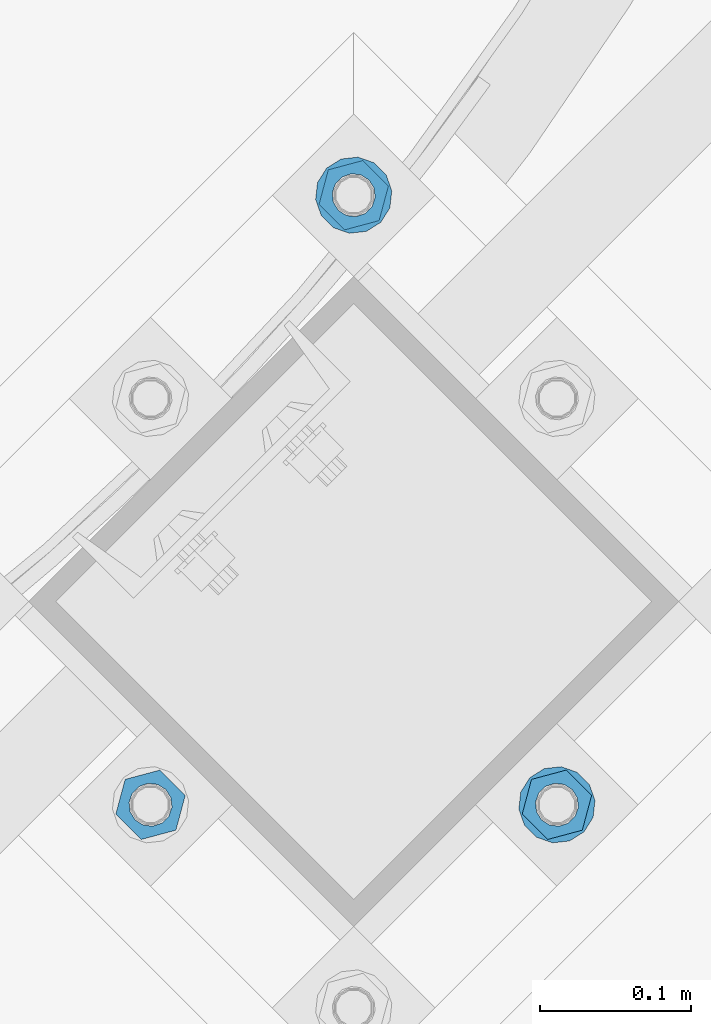
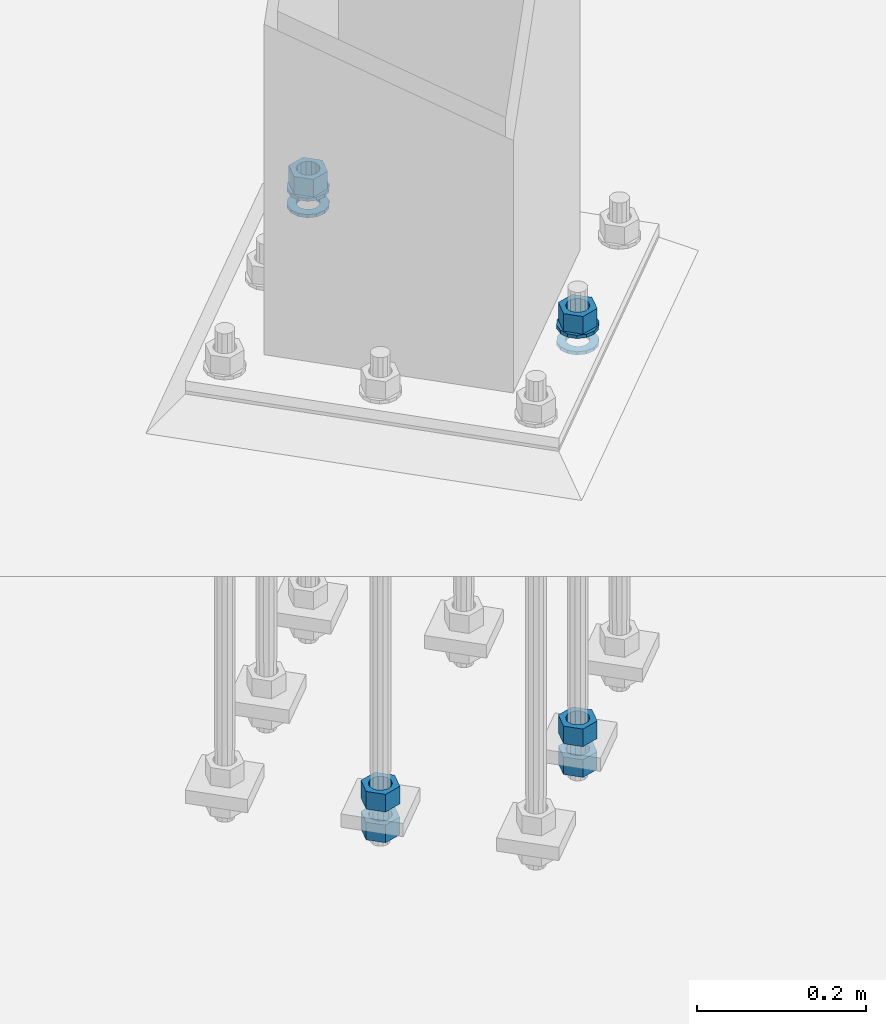
# One storey, part 882 of 1876: 10 columns, 1 element without a shape of its own.
"""IFC2X3 building model written with IfcOpenShell, lengths in millimetres."""

from ifc_helpers import new_model, si_unit, frame, origin_with_axes, place, context, subcontext, project, spatial, faceted_brep, material, type_object, element, aggregate, save


model = new_model("IFC2X3")

# Units and contexts
model_context = context("Model", 3, precision=1e-05, world=origin_with_axes())
body_context = subcontext(model_context, "Body", "Model", "MODEL_VIEW")
ifc_project = project(units=[si_unit("LENGTHUNIT", "METRE", prefix="MILLI"), si_unit("AREAUNIT", "SQUARE_METRE"), si_unit("VOLUMEUNIT", "CUBIC_METRE"), si_unit("MASSUNIT", "GRAM", prefix="KILO"), si_unit("TIMEUNIT", "SECOND"), si_unit("PLANEANGLEUNIT", "RADIAN"), si_unit("SOLIDANGLEUNIT", "STERADIAN"), si_unit("THERMODYNAMICTEMPERATUREUNIT", "DEGREE_CELSIUS"), si_unit("LUMINOUSINTENSITYUNIT", "LUMEN")], contexts=[model_context])

# Site, building, storey
site_placement = place(None, origin_with_axes())
site = spatial("IfcSite", under=ifc_project, at=site_placement, CompositionType="ELEMENT")
building_placement = place(site_placement, origin_with_axes())
building = spatial("IfcBuilding", under=site, at=building_placement, Name="Undefined", CompositionType="ELEMENT")
storey_placement = place(building_placement, origin_with_axes())
storey = spatial("IfcBuildingStorey", under=building, at=storey_placement, Name="Undefined", CompositionType="ELEMENT", Elevation=0.0)

# Assembly, columns
assembly_placement = place(storey_placement, origin_with_axes())
assembly = element("IfcElementAssembly", 1, at=assembly_placement, inside=storey, Name="TEMPLATE", AssemblyPlace="NOTDEFINED", PredefinedType="RIGID_FRAME")
ifc_material_1 = material(Name="STEEL/A563")
column_type_1 = type_object("IfcColumnType", Name="1_HEAVY_HEX_NUT", PredefinedType="NOTDEFINED")
column_1_placement = place(assembly_placement, frame((6580.27820529301, -10666.824706778, 87.3125), z_axis=(-0.707106781186547, -0.707106781186548, 0.0), x_axis=(0.0, 0.0, -1.0)))
column_1 = element("IfcColumn", 2, at=column_1_placement, type_object=column_type_1, material=ifc_material_1, Name="NUT", ObjectType="1_HEAVY_HEX_NUT", context=body_context, shape_type="Brep", body=[
    faceted_brep([(0.0, -23.8099994659442, 9.09494701772928e-13), (0.0, -11.9099998474121, -20.6200008392352), (25.4, -11.9099998474157, -20.6200008392361), (25.4, -23.8099994659478, 0.0), (0.0, 11.9099998474157, -20.620000839237), (25.4, 11.9099998474121, -20.620000839237), (0.0, 23.8099994659478, 9.09494701772928e-13), (25.4, 23.8099994659442, 0.0), (0.0, 11.9099998474157, 20.620000839237), (25.4, 11.9099998474121, 20.620000839237), (0.0, -11.9099998474121, 20.6200008392389), (25.4, -11.9099998474157, 20.6200008392379), (0.0, 1.81898940354586e-12, 14.2899999618567), (0.0, 6.20019861543915, 12.8748450879584), (25.4, 6.20019861543733, 12.8748450879593), (25.4, 0.0, 14.2899999618558), (0.0, 11.1723718546473, 8.90966924477925), (25.4, 11.1723718546436, 8.90966924477925), (0.0, 13.9317198278914, 3.17982413774916), (25.4, 13.9317198278877, 3.17982413775007), (0.0, 13.9317198278914, -3.17982413774644), (25.4, 13.9317198278895, -3.17982413774735), (0.0, 11.1723718546473, -8.90966924477834), (25.4, 11.1723718546455, -8.90966924477925), (0.0, 6.20019861544279, -12.8748450879575), (25.4, 6.20019861543915, -12.8748450879584), (0.0, 3.63797880709171e-12, -14.2899999618548), (25.4, -3.63797880709171e-12, -14.2899999618548), (0.0, -6.20019861543733, -12.8748450879566), (25.4, -6.20019861544097, -12.8748450879584), (0.0, -11.1723718546455, -8.90966924477743), (25.4, -11.1723718546473, -8.90966924477834), (0.0, -13.9317198278877, -3.17982413774735), (25.4, -13.9317198278914, -3.17982413774826), (0.0, -13.9317198278895, 3.17982413774735), (25.4, -13.9317198278914, 3.17982413774826), (0.0, -11.1723718546455, 8.90966924477925), (25.4, -11.1723718546473, 8.90966924478016), (0.0, -6.20019861543915, 12.8748450879593), (25.4, -6.20019861544279, 12.8748450879593)], [[[0, 1, 2, 3]], [[1, 4, 5, 2]], [[4, 6, 7, 5]], [[6, 8, 9, 7]], [[8, 10, 11, 9]], [[10, 0, 3, 11]], [[12, 13, 14, 15]], [[13, 16, 17, 14]], [[16, 18, 19, 17]], [[18, 20, 21, 19]], [[20, 22, 23, 21]], [[22, 24, 25, 23]], [[24, 26, 27, 25]], [[26, 28, 29, 27]], [[28, 30, 31, 29]], [[30, 32, 33, 31]], [[32, 34, 35, 33]], [[34, 36, 37, 35]], [[36, 38, 39, 37]], [[38, 12, 15, 39]], [[5, 7, 9, 11, 3, 2], [17, 19, 21, 23, 25, 27, 29, 31, 33, 35, 37, 39, 15, 14]], [[10, 8, 6, 4, 1, 0], [38, 36, 34, 32, 30, 28, 26, 24, 22, 20, 18, 16, 13, 12]]]),
])
column_2_placement = place(assembly_placement, frame((6714.98204710916, -11070.9362322265, 87.3125), z_axis=(0.707106781186548, 0.707106781186547, 0.0), x_axis=(0.0, 0.0, -1.0)))
column_2 = element("IfcColumn", 3, at=column_2_placement, type_object=column_type_1, material=ifc_material_1, Name="NUT", ObjectType="1_HEAVY_HEX_NUT", context=body_context, shape_type="Brep", body=[
    faceted_brep([(0.0, -23.8099994659442, 9.09494701772928e-13), (0.0, -11.9099998474121, -20.6200008392352), (25.4, -11.9099998474157, -20.6200008392361), (25.4, -23.8099994659478, 0.0), (0.0, 11.9099998474157, -20.620000839237), (25.4, 11.9099998474121, -20.620000839237), (0.0, 23.8099994659478, 9.09494701772928e-13), (25.4, 23.8099994659442, 0.0), (0.0, 11.9099998474157, 20.620000839237), (25.4, 11.9099998474121, 20.620000839237), (0.0, -11.9099998474121, 20.6200008392389), (25.4, -11.9099998474157, 20.6200008392379), (0.0, 1.81898940354586e-12, 14.2899999618567), (0.0, 6.20019861543915, 12.8748450879584), (25.4, 6.20019861543733, 12.8748450879593), (25.4, 0.0, 14.2899999618558), (0.0, 11.1723718546473, 8.90966924477925), (25.4, 11.1723718546436, 8.90966924477925), (0.0, 13.9317198278914, 3.17982413774916), (25.4, 13.9317198278877, 3.17982413775007), (0.0, 13.9317198278914, -3.17982413774644), (25.4, 13.9317198278895, -3.17982413774735), (0.0, 11.1723718546473, -8.90966924477834), (25.4, 11.1723718546455, -8.90966924477925), (0.0, 6.20019861544279, -12.8748450879575), (25.4, 6.20019861543915, -12.8748450879584), (0.0, 3.63797880709171e-12, -14.2899999618548), (25.4, -3.63797880709171e-12, -14.2899999618548), (0.0, -6.20019861543733, -12.8748450879566), (25.4, -6.20019861544097, -12.8748450879584), (0.0, -11.1723718546455, -8.90966924477743), (25.4, -11.1723718546473, -8.90966924477834), (0.0, -13.9317198278877, -3.17982413774735), (25.4, -13.9317198278914, -3.17982413774826), (0.0, -13.9317198278895, 3.17982413774735), (25.4, -13.9317198278914, 3.17982413774826), (0.0, -11.1723718546455, 8.90966924477925), (25.4, -11.1723718546473, 8.90966924478016), (0.0, -6.20019861543915, 12.8748450879593), (25.4, -6.20019861544279, 12.8748450879593)], [[[0, 1, 2, 3]], [[1, 4, 5, 2]], [[4, 6, 7, 5]], [[6, 8, 9, 7]], [[8, 10, 11, 9]], [[10, 0, 3, 11]], [[12, 13, 14, 15]], [[13, 16, 17, 14]], [[16, 18, 19, 17]], [[18, 20, 21, 19]], [[20, 22, 23, 21]], [[22, 24, 25, 23]], [[24, 26, 27, 25]], [[26, 28, 29, 27]], [[28, 30, 31, 29]], [[30, 32, 33, 31]], [[32, 34, 35, 33]], [[34, 36, 37, 35]], [[36, 38, 39, 37]], [[38, 12, 15, 39]], [[5, 7, 9, 11, 3, 2], [17, 19, 21, 23, 25, 27, 29, 31, 33, 35, 37, 39, 15, 14]], [[10, 8, 6, 4, 1, 0], [38, 36, 34, 32, 30, 28, 26, 24, 22, 20, 18, 16, 13, 12]]]),
])
column_3_placement = place(assembly_placement, frame((6714.98204710916, -11070.9362322265, -508.0), z_axis=(0.707106781186548, 0.707106781186547, 0.0), x_axis=(0.0, 0.0, -1.0)))
column_3 = element("IfcColumn", 4, at=column_3_placement, type_object=column_type_1, material=ifc_material_1, Name="NUT", ObjectType="1_HEAVY_HEX_NUT", context=body_context, shape_type="Brep", body=[
    faceted_brep([(0.0, -23.8099994659442, 9.09494701772928e-13), (0.0, -11.9099998474121, -20.6200008392352), (25.4, -11.9099998474157, -20.6200008392361), (25.4, -23.8099994659478, 0.0), (0.0, 11.9099998474157, -20.620000839237), (25.4, 11.9099998474121, -20.620000839237), (0.0, 23.8099994659478, 9.09494701772928e-13), (25.4, 23.8099994659442, 0.0), (0.0, 11.9099998474157, 20.620000839237), (25.4, 11.9099998474121, 20.620000839237), (0.0, -11.9099998474121, 20.6200008392389), (25.4, -11.9099998474157, 20.6200008392379), (0.0, 1.81898940354586e-12, 14.2899999618567), (0.0, 6.20019861543915, 12.8748450879584), (25.4, 6.20019861543733, 12.8748450879593), (25.4, 0.0, 14.2899999618558), (0.0, 11.1723718546473, 8.90966924477925), (25.4, 11.1723718546436, 8.90966924477925), (0.0, 13.9317198278914, 3.17982413774916), (25.4, 13.9317198278877, 3.17982413775007), (0.0, 13.9317198278914, -3.17982413774644), (25.4, 13.9317198278895, -3.17982413774735), (0.0, 11.1723718546473, -8.90966924477834), (25.4, 11.1723718546455, -8.90966924477925), (0.0, 6.20019861544279, -12.8748450879575), (25.4, 6.20019861543915, -12.8748450879584), (0.0, 3.63797880709171e-12, -14.2899999618548), (25.4, -3.63797880709171e-12, -14.2899999618548), (0.0, -6.20019861543733, -12.8748450879566), (25.4, -6.20019861544097, -12.8748450879584), (0.0, -11.1723718546455, -8.90966924477743), (25.4, -11.1723718546473, -8.90966924477834), (0.0, -13.9317198278877, -3.17982413774735), (25.4, -13.9317198278914, -3.17982413774826), (0.0, -13.9317198278895, 3.17982413774735), (25.4, -13.9317198278914, 3.17982413774826), (0.0, -11.1723718546455, 8.90966924477925), (25.4, -11.1723718546473, 8.90966924478016), (0.0, -6.20019861543915, 12.8748450879593), (25.4, -6.20019861544279, 12.8748450879593)], [[[0, 1, 2, 3]], [[1, 4, 5, 2]], [[4, 6, 7, 5]], [[6, 8, 9, 7]], [[8, 10, 11, 9]], [[10, 0, 3, 11]], [[12, 13, 14, 15]], [[13, 16, 17, 14]], [[16, 18, 19, 17]], [[18, 20, 21, 19]], [[20, 22, 23, 21]], [[22, 24, 25, 23]], [[24, 26, 27, 25]], [[26, 28, 29, 27]], [[28, 30, 31, 29]], [[30, 32, 33, 31]], [[32, 34, 35, 33]], [[34, 36, 37, 35]], [[36, 38, 39, 37]], [[38, 12, 15, 39]], [[5, 7, 9, 11, 3, 2], [17, 19, 21, 23, 25, 27, 29, 31, 33, 35, 37, 39, 15, 14]], [[10, 8, 6, 4, 1, 0], [38, 36, 34, 32, 30, 28, 26, 24, 22, 20, 18, 16, 13, 12]]]),
])
column_4_placement = place(assembly_placement, frame((6714.98204710916, -11070.9362322265, -552.45), z_axis=(0.707106781186548, 0.707106781186547, 0.0), x_axis=(0.0, 0.0, -1.0)))
column_4 = element("IfcColumn", 5, at=column_4_placement, type_object=column_type_1, material=ifc_material_1, Name="NUT", ObjectType="1_HEAVY_HEX_NUT", context=body_context, shape_type="Brep", body=[
    faceted_brep([(0.0, -23.8099994659442, 9.09494701772928e-13), (0.0, -11.9099998474121, -20.6200008392352), (25.4, -11.9099998474157, -20.6200008392361), (25.4, -23.8099994659478, 0.0), (0.0, 11.9099998474157, -20.620000839237), (25.4, 11.9099998474121, -20.620000839237), (0.0, 23.8099994659478, 9.09494701772928e-13), (25.4, 23.8099994659442, 0.0), (0.0, 11.9099998474157, 20.620000839237), (25.4, 11.9099998474121, 20.620000839237), (0.0, -11.9099998474121, 20.6200008392389), (25.4, -11.9099998474157, 20.6200008392379), (0.0, 1.81898940354586e-12, 14.2899999618567), (0.0, 6.20019861543915, 12.8748450879584), (25.4, 6.20019861543733, 12.8748450879593), (25.4, 0.0, 14.2899999618558), (0.0, 11.1723718546473, 8.90966924477925), (25.4, 11.1723718546436, 8.90966924477925), (0.0, 13.9317198278914, 3.17982413774916), (25.4, 13.9317198278877, 3.17982413775007), (0.0, 13.9317198278914, -3.17982413774644), (25.4, 13.9317198278895, -3.17982413774735), (0.0, 11.1723718546473, -8.90966924477834), (25.4, 11.1723718546455, -8.90966924477925), (0.0, 6.20019861544279, -12.8748450879575), (25.4, 6.20019861543915, -12.8748450879584), (0.0, 3.63797880709171e-12, -14.2899999618548), (25.4, -3.63797880709171e-12, -14.2899999618548), (0.0, -6.20019861543733, -12.8748450879566), (25.4, -6.20019861544097, -12.8748450879584), (0.0, -11.1723718546455, -8.90966924477743), (25.4, -11.1723718546473, -8.90966924477834), (0.0, -13.9317198278877, -3.17982413774735), (25.4, -13.9317198278914, -3.17982413774826), (0.0, -13.9317198278895, 3.17982413774735), (25.4, -13.9317198278914, 3.17982413774826), (0.0, -11.1723718546455, 8.90966924477925), (25.4, -11.1723718546473, 8.90966924478016), (0.0, -6.20019861543915, 12.8748450879593), (25.4, -6.20019861544279, 12.8748450879593)], [[[0, 1, 2, 3]], [[1, 4, 5, 2]], [[4, 6, 7, 5]], [[6, 8, 9, 7]], [[8, 10, 11, 9]], [[10, 0, 3, 11]], [[12, 13, 14, 15]], [[13, 16, 17, 14]], [[16, 18, 19, 17]], [[18, 20, 21, 19]], [[20, 22, 23, 21]], [[22, 24, 25, 23]], [[24, 26, 27, 25]], [[26, 28, 29, 27]], [[28, 30, 31, 29]], [[30, 32, 33, 31]], [[32, 34, 35, 33]], [[34, 36, 37, 35]], [[36, 38, 39, 37]], [[38, 12, 15, 39]], [[5, 7, 9, 11, 3, 2], [17, 19, 21, 23, 25, 27, 29, 31, 33, 35, 37, 39, 15, 14]], [[10, 8, 6, 4, 1, 0], [38, 36, 34, 32, 30, 28, 26, 24, 22, 20, 18, 16, 13, 12]]]),
])
column_5_placement = place(assembly_placement, frame((6445.57436347686, -11070.9362322265, -508.0), z_axis=(0.707106781186548, 0.707106781186547, 0.0), x_axis=(0.0, 0.0, -1.0)))
column_5 = element("IfcColumn", 6, at=column_5_placement, type_object=column_type_1, material=ifc_material_1, Name="NUT", ObjectType="1_HEAVY_HEX_NUT", context=body_context, shape_type="Brep", body=[
    faceted_brep([(0.0, -23.8099994659442, 9.09494701772928e-13), (0.0, -11.9099998474121, -20.6200008392352), (25.4, -11.9099998474157, -20.6200008392361), (25.4, -23.8099994659478, 0.0), (0.0, 11.9099998474157, -20.620000839237), (25.4, 11.9099998474121, -20.620000839237), (0.0, 23.8099994659478, 9.09494701772928e-13), (25.4, 23.8099994659442, 0.0), (0.0, 11.9099998474157, 20.620000839237), (25.4, 11.9099998474121, 20.620000839237), (0.0, -11.9099998474121, 20.6200008392389), (25.4, -11.9099998474157, 20.6200008392379), (0.0, 1.81898940354586e-12, 14.2899999618567), (0.0, 6.20019861543915, 12.8748450879584), (25.4, 6.20019861543733, 12.8748450879593), (25.4, 0.0, 14.2899999618558), (0.0, 11.1723718546473, 8.90966924477925), (25.4, 11.1723718546436, 8.90966924477925), (0.0, 13.9317198278914, 3.17982413774916), (25.4, 13.9317198278877, 3.17982413775007), (0.0, 13.9317198278914, -3.17982413774644), (25.4, 13.9317198278895, -3.17982413774735), (0.0, 11.1723718546473, -8.90966924477834), (25.4, 11.1723718546455, -8.90966924477925), (0.0, 6.20019861544279, -12.8748450879575), (25.4, 6.20019861543915, -12.8748450879584), (0.0, 3.63797880709171e-12, -14.2899999618548), (25.4, -3.63797880709171e-12, -14.2899999618548), (0.0, -6.20019861543733, -12.8748450879566), (25.4, -6.20019861544097, -12.8748450879584), (0.0, -11.1723718546455, -8.90966924477743), (25.4, -11.1723718546473, -8.90966924477834), (0.0, -13.9317198278877, -3.17982413774735), (25.4, -13.9317198278914, -3.17982413774826), (0.0, -13.9317198278895, 3.17982413774735), (25.4, -13.9317198278914, 3.17982413774826), (0.0, -11.1723718546455, 8.90966924477925), (25.4, -11.1723718546473, 8.90966924478016), (0.0, -6.20019861543915, 12.8748450879593), (25.4, -6.20019861544279, 12.8748450879593)], [[[0, 1, 2, 3]], [[1, 4, 5, 2]], [[4, 6, 7, 5]], [[6, 8, 9, 7]], [[8, 10, 11, 9]], [[10, 0, 3, 11]], [[12, 13, 14, 15]], [[13, 16, 17, 14]], [[16, 18, 19, 17]], [[18, 20, 21, 19]], [[20, 22, 23, 21]], [[22, 24, 25, 23]], [[24, 26, 27, 25]], [[26, 28, 29, 27]], [[28, 30, 31, 29]], [[30, 32, 33, 31]], [[32, 34, 35, 33]], [[34, 36, 37, 35]], [[36, 38, 39, 37]], [[38, 12, 15, 39]], [[5, 7, 9, 11, 3, 2], [17, 19, 21, 23, 25, 27, 29, 31, 33, 35, 37, 39, 15, 14]], [[10, 8, 6, 4, 1, 0], [38, 36, 34, 32, 30, 28, 26, 24, 22, 20, 18, 16, 13, 12]]]),
])
column_6_placement = place(assembly_placement, frame((6445.57436347686, -11070.9362322265, -552.45), z_axis=(0.707106781186548, 0.707106781186547, 0.0), x_axis=(0.0, 0.0, -1.0)))
column_6 = element("IfcColumn", 7, at=column_6_placement, type_object=column_type_1, material=ifc_material_1, Name="NUT", ObjectType="1_HEAVY_HEX_NUT", context=body_context, shape_type="Brep", body=[
    faceted_brep([(0.0, -23.8099994659442, 9.09494701772928e-13), (0.0, -11.9099998474121, -20.6200008392352), (25.4, -11.9099998474157, -20.6200008392361), (25.4, -23.8099994659478, 0.0), (0.0, 11.9099998474157, -20.620000839237), (25.4, 11.9099998474121, -20.620000839237), (0.0, 23.8099994659478, 9.09494701772928e-13), (25.4, 23.8099994659442, 0.0), (0.0, 11.9099998474157, 20.620000839237), (25.4, 11.9099998474121, 20.620000839237), (0.0, -11.9099998474121, 20.6200008392389), (25.4, -11.9099998474157, 20.6200008392379), (0.0, 1.81898940354586e-12, 14.2899999618567), (0.0, 6.20019861543915, 12.8748450879584), (25.4, 6.20019861543733, 12.8748450879593), (25.4, 0.0, 14.2899999618558), (0.0, 11.1723718546473, 8.90966924477925), (25.4, 11.1723718546436, 8.90966924477925), (0.0, 13.9317198278914, 3.17982413774916), (25.4, 13.9317198278877, 3.17982413775007), (0.0, 13.9317198278914, -3.17982413774644), (25.4, 13.9317198278895, -3.17982413774735), (0.0, 11.1723718546473, -8.90966924477834), (25.4, 11.1723718546455, -8.90966924477925), (0.0, 6.20019861544279, -12.8748450879575), (25.4, 6.20019861543915, -12.8748450879584), (0.0, 3.63797880709171e-12, -14.2899999618548), (25.4, -3.63797880709171e-12, -14.2899999618548), (0.0, -6.20019861543733, -12.8748450879566), (25.4, -6.20019861544097, -12.8748450879584), (0.0, -11.1723718546455, -8.90966924477743), (25.4, -11.1723718546473, -8.90966924477834), (0.0, -13.9317198278877, -3.17982413774735), (25.4, -13.9317198278914, -3.17982413774826), (0.0, -13.9317198278895, 3.17982413774735), (25.4, -13.9317198278914, 3.17982413774826), (0.0, -11.1723718546455, 8.90966924477925), (25.4, -11.1723718546473, 8.90966924478016), (0.0, -6.20019861543915, 12.8748450879593), (25.4, -6.20019861544279, 12.8748450879593)], [[[0, 1, 2, 3]], [[1, 4, 5, 2]], [[4, 6, 7, 5]], [[6, 8, 9, 7]], [[8, 10, 11, 9]], [[10, 0, 3, 11]], [[12, 13, 14, 15]], [[13, 16, 17, 14]], [[16, 18, 19, 17]], [[18, 20, 21, 19]], [[20, 22, 23, 21]], [[22, 24, 25, 23]], [[24, 26, 27, 25]], [[26, 28, 29, 27]], [[28, 30, 31, 29]], [[30, 32, 33, 31]], [[32, 34, 35, 33]], [[34, 36, 37, 35]], [[36, 38, 39, 37]], [[38, 12, 15, 39]], [[5, 7, 9, 11, 3, 2], [17, 19, 21, 23, 25, 27, 29, 31, 33, 35, 37, 39, 15, 14]], [[10, 8, 6, 4, 1, 0], [38, 36, 34, 32, 30, 28, 26, 24, 22, 20, 18, 16, 13, 12]]]),
])
ifc_material_2 = material(Name="STEEL/F436")
column_type_2 = type_object("IfcColumnType", Name="1_WASHER", PredefinedType="NOTDEFINED")
column_7_placement = place(assembly_placement, frame((6580.27820529301, -10666.824706778, 38.1), z_axis=(-0.707106781186547, -0.707106781186548, 0.0), x_axis=(0.0, 0.0, -1.0)))
column_7 = element("IfcColumn", 8, at=column_7_placement, type_object=column_type_2, material=ifc_material_2, Name="WASHER", ObjectType="1_WASHER", context=body_context, shape_type="Brep", body=[
    faceted_brep([(0.0, -25.3999996185375, 0.0), (0.0, -22.8846089010331, -11.0206468080742), (4.7625, -22.8846089010331, -11.0206468080742), (4.7625, -25.3999996185375, 0.0), (0.0, -15.8366407293743, -19.8585193564477), (4.7625, -15.8366407293743, -19.8585193564477), (0.0, -5.65203163760816, -24.7631685975166), (4.7625, -5.65203163760816, -24.7631685975166), (0.0, 5.65203163760452, -24.7631685975166), (4.7625, 5.65203163760452, -24.7631685975166), (0.0, 15.8366407293706, -19.858519356445), (4.7625, 15.8366407293706, -19.858519356445), (0.0, 22.8846089010331, -11.0206468080733), (4.7625, 22.8846089010331, -11.0206468080733), (0.0, 25.3999996185339, 9.09494701772928e-13), (4.7625, 25.3999996185339, 9.09494701772928e-13), (0.0, 22.8846089010331, 11.0206468080751), (4.7625, 22.8846089010331, 11.0206468080751), (0.0, 15.8366407293706, 19.8585193564486), (4.7625, 15.8366407293706, 19.8585193564486), (0.0, 5.65203163760452, 24.7631685975175), (4.7625, 5.65203163760452, 24.7631685975175), (0.0, -5.65203163760816, 24.7631685975175), (4.7625, -5.65203163760816, 24.7631685975175), (0.0, -15.8366407293724, 19.8585193564459), (4.7625, -15.8366407293724, 19.8585193564459), (0.0, -22.8846089010367, 11.0206468080751), (4.7625, -22.8846089010367, 11.0206468080751), (0.0, 1.81898940354586e-12, 14.2899999618567), (0.0, 6.20019861543915, 12.8748450879584), (4.7625, 6.20019861543733, 12.8748450879593), (4.7625, 0.0, 14.2899999618558), (0.0, 11.1723718546473, 8.90966924477925), (4.7625, 11.1723718546436, 8.90966924477925), (0.0, 13.9317198278914, 3.17982413774916), (4.7625, 13.9317198278877, 3.17982413775007), (0.0, 13.9317198278914, -3.17982413774644), (4.7625, 13.9317198278895, -3.17982413774735), (0.0, 11.1723718546473, -8.90966924477834), (4.7625, 11.1723718546455, -8.90966924477925), (0.0, 6.20019861544279, -12.8748450879575), (4.7625, 6.20019861543915, -12.8748450879584), (0.0, 3.63797880709171e-12, -14.2899999618548), (4.7625, -3.63797880709171e-12, -14.2899999618548), (0.0, -6.20019861543733, -12.8748450879566), (4.7625, -6.20019861544097, -12.8748450879584), (0.0, -11.1723718546455, -8.90966924477743), (4.7625, -11.1723718546473, -8.90966924477834), (0.0, -13.9317198278877, -3.17982413774735), (4.7625, -13.9317198278914, -3.17982413774826), (0.0, -13.9317198278895, 3.17982413774735), (4.7625, -13.9317198278914, 3.17982413774826), (0.0, -11.1723718546455, 8.90966924477925), (4.7625, -11.1723718546473, 8.90966924478016), (0.0, -6.20019861543915, 12.8748450879593), (4.7625, -6.20019861544279, 12.8748450879593)], [[[0, 1, 2, 3]], [[1, 4, 5, 2]], [[4, 6, 7, 5]], [[6, 8, 9, 7]], [[8, 10, 11, 9]], [[10, 12, 13, 11]], [[12, 14, 15, 13]], [[14, 16, 17, 15]], [[16, 18, 19, 17]], [[18, 20, 21, 19]], [[20, 22, 23, 21]], [[22, 24, 25, 23]], [[24, 26, 27, 25]], [[26, 0, 3, 27]], [[28, 29, 30, 31]], [[29, 32, 33, 30]], [[32, 34, 35, 33]], [[34, 36, 37, 35]], [[36, 38, 39, 37]], [[38, 40, 41, 39]], [[40, 42, 43, 41]], [[42, 44, 45, 43]], [[44, 46, 47, 45]], [[46, 48, 49, 47]], [[48, 50, 51, 49]], [[50, 52, 53, 51]], [[52, 54, 55, 53]], [[54, 28, 31, 55]], [[5, 7, 9, 11, 13, 15, 17, 19, 21, 23, 25, 27, 3, 2], [33, 35, 37, 39, 41, 43, 45, 47, 49, 51, 53, 55, 31, 30]], [[26, 24, 22, 20, 18, 16, 14, 12, 10, 8, 6, 4, 1, 0], [54, 52, 50, 48, 46, 44, 42, 40, 38, 36, 34, 32, 29, 28]]]),
])
column_8_placement = place(assembly_placement, frame((6580.27820529301, -10666.824706778, 61.9125), z_axis=(-0.707106781186547, -0.707106781186548, 0.0), x_axis=(0.0, 0.0, -1.0)))
column_8 = element("IfcColumn", 9, at=column_8_placement, type_object=column_type_2, material=ifc_material_2, Name="WASHER", ObjectType="1_WASHER", context=body_context, shape_type="Brep", body=[
    faceted_brep([(0.0, -25.3999996185375, 0.0), (0.0, -22.8846089010331, -11.0206468080742), (4.7625, -22.8846089010331, -11.0206468080742), (4.7625, -25.3999996185375, 0.0), (0.0, -15.8366407293743, -19.8585193564477), (4.7625, -15.8366407293743, -19.8585193564477), (0.0, -5.65203163760816, -24.7631685975166), (4.7625, -5.65203163760816, -24.7631685975166), (0.0, 5.65203163760452, -24.7631685975166), (4.7625, 5.65203163760452, -24.7631685975166), (0.0, 15.8366407293706, -19.858519356445), (4.7625, 15.8366407293706, -19.858519356445), (0.0, 22.8846089010331, -11.0206468080733), (4.7625, 22.8846089010331, -11.0206468080733), (0.0, 25.3999996185339, 9.09494701772928e-13), (4.7625, 25.3999996185339, 9.09494701772928e-13), (0.0, 22.8846089010331, 11.0206468080751), (4.7625, 22.8846089010331, 11.0206468080751), (0.0, 15.8366407293706, 19.8585193564486), (4.7625, 15.8366407293706, 19.8585193564486), (0.0, 5.65203163760452, 24.7631685975175), (4.7625, 5.65203163760452, 24.7631685975175), (0.0, -5.65203163760816, 24.7631685975175), (4.7625, -5.65203163760816, 24.7631685975175), (0.0, -15.8366407293724, 19.8585193564459), (4.7625, -15.8366407293724, 19.8585193564459), (0.0, -22.8846089010367, 11.0206468080751), (4.7625, -22.8846089010367, 11.0206468080751), (0.0, 1.81898940354586e-12, 14.2899999618567), (0.0, 6.20019861543915, 12.8748450879584), (4.7625, 6.20019861543733, 12.8748450879593), (4.7625, 0.0, 14.2899999618558), (0.0, 11.1723718546473, 8.90966924477925), (4.7625, 11.1723718546436, 8.90966924477925), (0.0, 13.9317198278914, 3.17982413774916), (4.7625, 13.9317198278877, 3.17982413775007), (0.0, 13.9317198278914, -3.17982413774644), (4.7625, 13.9317198278895, -3.17982413774735), (0.0, 11.1723718546473, -8.90966924477834), (4.7625, 11.1723718546455, -8.90966924477925), (0.0, 6.20019861544279, -12.8748450879575), (4.7625, 6.20019861543915, -12.8748450879584), (0.0, 3.63797880709171e-12, -14.2899999618548), (4.7625, -3.63797880709171e-12, -14.2899999618548), (0.0, -6.20019861543733, -12.8748450879566), (4.7625, -6.20019861544097, -12.8748450879584), (0.0, -11.1723718546455, -8.90966924477743), (4.7625, -11.1723718546473, -8.90966924477834), (0.0, -13.9317198278877, -3.17982413774735), (4.7625, -13.9317198278914, -3.17982413774826), (0.0, -13.9317198278895, 3.17982413774735), (4.7625, -13.9317198278914, 3.17982413774826), (0.0, -11.1723718546455, 8.90966924477925), (4.7625, -11.1723718546473, 8.90966924478016), (0.0, -6.20019861543915, 12.8748450879593), (4.7625, -6.20019861544279, 12.8748450879593)], [[[0, 1, 2, 3]], [[1, 4, 5, 2]], [[4, 6, 7, 5]], [[6, 8, 9, 7]], [[8, 10, 11, 9]], [[10, 12, 13, 11]], [[12, 14, 15, 13]], [[14, 16, 17, 15]], [[16, 18, 19, 17]], [[18, 20, 21, 19]], [[20, 22, 23, 21]], [[22, 24, 25, 23]], [[24, 26, 27, 25]], [[26, 0, 3, 27]], [[28, 29, 30, 31]], [[29, 32, 33, 30]], [[32, 34, 35, 33]], [[34, 36, 37, 35]], [[36, 38, 39, 37]], [[38, 40, 41, 39]], [[40, 42, 43, 41]], [[42, 44, 45, 43]], [[44, 46, 47, 45]], [[46, 48, 49, 47]], [[48, 50, 51, 49]], [[50, 52, 53, 51]], [[52, 54, 55, 53]], [[54, 28, 31, 55]], [[5, 7, 9, 11, 13, 15, 17, 19, 21, 23, 25, 27, 3, 2], [33, 35, 37, 39, 41, 43, 45, 47, 49, 51, 53, 55, 31, 30]], [[26, 24, 22, 20, 18, 16, 14, 12, 10, 8, 6, 4, 1, 0], [54, 52, 50, 48, 46, 44, 42, 40, 38, 36, 34, 32, 29, 28]]]),
])
column_9_placement = place(assembly_placement, frame((6714.98204710916, -11070.9362322265, 38.1), z_axis=(0.707106781186548, 0.707106781186547, 0.0), x_axis=(0.0, 0.0, -1.0)))
column_9 = element("IfcColumn", 10, at=column_9_placement, type_object=column_type_2, material=ifc_material_2, Name="WASHER", ObjectType="1_WASHER", context=body_context, shape_type="Brep", body=[
    faceted_brep([(0.0, -25.3999996185375, 0.0), (0.0, -22.8846089010331, -11.0206468080742), (4.7625, -22.8846089010331, -11.0206468080742), (4.7625, -25.3999996185375, 0.0), (0.0, -15.8366407293743, -19.8585193564477), (4.7625, -15.8366407293743, -19.8585193564477), (0.0, -5.65203163760816, -24.7631685975166), (4.7625, -5.65203163760816, -24.7631685975166), (0.0, 5.65203163760452, -24.7631685975166), (4.7625, 5.65203163760452, -24.7631685975166), (0.0, 15.8366407293706, -19.858519356445), (4.7625, 15.8366407293706, -19.858519356445), (0.0, 22.8846089010331, -11.0206468080733), (4.7625, 22.8846089010331, -11.0206468080733), (0.0, 25.3999996185339, 9.09494701772928e-13), (4.7625, 25.3999996185339, 9.09494701772928e-13), (0.0, 22.8846089010331, 11.0206468080751), (4.7625, 22.8846089010331, 11.0206468080751), (0.0, 15.8366407293706, 19.8585193564486), (4.7625, 15.8366407293706, 19.8585193564486), (0.0, 5.65203163760452, 24.7631685975175), (4.7625, 5.65203163760452, 24.7631685975175), (0.0, -5.65203163760816, 24.7631685975175), (4.7625, -5.65203163760816, 24.7631685975175), (0.0, -15.8366407293724, 19.8585193564459), (4.7625, -15.8366407293724, 19.8585193564459), (0.0, -22.8846089010367, 11.0206468080751), (4.7625, -22.8846089010367, 11.0206468080751), (0.0, 1.81898940354586e-12, 14.2899999618567), (0.0, 6.20019861543915, 12.8748450879584), (4.7625, 6.20019861543733, 12.8748450879593), (4.7625, 0.0, 14.2899999618558), (0.0, 11.1723718546473, 8.90966924477925), (4.7625, 11.1723718546436, 8.90966924477925), (0.0, 13.9317198278914, 3.17982413774916), (4.7625, 13.9317198278877, 3.17982413775007), (0.0, 13.9317198278914, -3.17982413774644), (4.7625, 13.9317198278895, -3.17982413774735), (0.0, 11.1723718546473, -8.90966924477834), (4.7625, 11.1723718546455, -8.90966924477925), (0.0, 6.20019861544279, -12.8748450879575), (4.7625, 6.20019861543915, -12.8748450879584), (0.0, 3.63797880709171e-12, -14.2899999618548), (4.7625, -3.63797880709171e-12, -14.2899999618548), (0.0, -6.20019861543733, -12.8748450879566), (4.7625, -6.20019861544097, -12.8748450879584), (0.0, -11.1723718546455, -8.90966924477743), (4.7625, -11.1723718546473, -8.90966924477834), (0.0, -13.9317198278877, -3.17982413774735), (4.7625, -13.9317198278914, -3.17982413774826), (0.0, -13.9317198278895, 3.17982413774735), (4.7625, -13.9317198278914, 3.17982413774826), (0.0, -11.1723718546455, 8.90966924477925), (4.7625, -11.1723718546473, 8.90966924478016), (0.0, -6.20019861543915, 12.8748450879593), (4.7625, -6.20019861544279, 12.8748450879593)], [[[0, 1, 2, 3]], [[1, 4, 5, 2]], [[4, 6, 7, 5]], [[6, 8, 9, 7]], [[8, 10, 11, 9]], [[10, 12, 13, 11]], [[12, 14, 15, 13]], [[14, 16, 17, 15]], [[16, 18, 19, 17]], [[18, 20, 21, 19]], [[20, 22, 23, 21]], [[22, 24, 25, 23]], [[24, 26, 27, 25]], [[26, 0, 3, 27]], [[28, 29, 30, 31]], [[29, 32, 33, 30]], [[32, 34, 35, 33]], [[34, 36, 37, 35]], [[36, 38, 39, 37]], [[38, 40, 41, 39]], [[40, 42, 43, 41]], [[42, 44, 45, 43]], [[44, 46, 47, 45]], [[46, 48, 49, 47]], [[48, 50, 51, 49]], [[50, 52, 53, 51]], [[52, 54, 55, 53]], [[54, 28, 31, 55]], [[5, 7, 9, 11, 13, 15, 17, 19, 21, 23, 25, 27, 3, 2], [33, 35, 37, 39, 41, 43, 45, 47, 49, 51, 53, 55, 31, 30]], [[26, 24, 22, 20, 18, 16, 14, 12, 10, 8, 6, 4, 1, 0], [54, 52, 50, 48, 46, 44, 42, 40, 38, 36, 34, 32, 29, 28]]]),
])
column_10_placement = place(assembly_placement, frame((6714.98204710916, -11070.9362322265, 61.9125), z_axis=(0.707106781186548, 0.707106781186547, 0.0), x_axis=(0.0, 0.0, -1.0)))
column_10 = element("IfcColumn", 11, at=column_10_placement, type_object=column_type_2, material=ifc_material_2, Name="WASHER", ObjectType="1_WASHER", context=body_context, shape_type="Brep", body=[
    faceted_brep([(0.0, -25.3999996185375, 0.0), (0.0, -22.8846089010331, -11.0206468080742), (4.7625, -22.8846089010331, -11.0206468080742), (4.7625, -25.3999996185375, 0.0), (0.0, -15.8366407293743, -19.8585193564477), (4.7625, -15.8366407293743, -19.8585193564477), (0.0, -5.65203163760816, -24.7631685975166), (4.7625, -5.65203163760816, -24.7631685975166), (0.0, 5.65203163760452, -24.7631685975166), (4.7625, 5.65203163760452, -24.7631685975166), (0.0, 15.8366407293706, -19.858519356445), (4.7625, 15.8366407293706, -19.858519356445), (0.0, 22.8846089010331, -11.0206468080733), (4.7625, 22.8846089010331, -11.0206468080733), (0.0, 25.3999996185339, 9.09494701772928e-13), (4.7625, 25.3999996185339, 9.09494701772928e-13), (0.0, 22.8846089010331, 11.0206468080751), (4.7625, 22.8846089010331, 11.0206468080751), (0.0, 15.8366407293706, 19.8585193564486), (4.7625, 15.8366407293706, 19.8585193564486), (0.0, 5.65203163760452, 24.7631685975175), (4.7625, 5.65203163760452, 24.7631685975175), (0.0, -5.65203163760816, 24.7631685975175), (4.7625, -5.65203163760816, 24.7631685975175), (0.0, -15.8366407293724, 19.8585193564459), (4.7625, -15.8366407293724, 19.8585193564459), (0.0, -22.8846089010367, 11.0206468080751), (4.7625, -22.8846089010367, 11.0206468080751), (0.0, 1.81898940354586e-12, 14.2899999618567), (0.0, 6.20019861543915, 12.8748450879584), (4.7625, 6.20019861543733, 12.8748450879593), (4.7625, 0.0, 14.2899999618558), (0.0, 11.1723718546473, 8.90966924477925), (4.7625, 11.1723718546436, 8.90966924477925), (0.0, 13.9317198278914, 3.17982413774916), (4.7625, 13.9317198278877, 3.17982413775007), (0.0, 13.9317198278914, -3.17982413774644), (4.7625, 13.9317198278895, -3.17982413774735), (0.0, 11.1723718546473, -8.90966924477834), (4.7625, 11.1723718546455, -8.90966924477925), (0.0, 6.20019861544279, -12.8748450879575), (4.7625, 6.20019861543915, -12.8748450879584), (0.0, 3.63797880709171e-12, -14.2899999618548), (4.7625, -3.63797880709171e-12, -14.2899999618548), (0.0, -6.20019861543733, -12.8748450879566), (4.7625, -6.20019861544097, -12.8748450879584), (0.0, -11.1723718546455, -8.90966924477743), (4.7625, -11.1723718546473, -8.90966924477834), (0.0, -13.9317198278877, -3.17982413774735), (4.7625, -13.9317198278914, -3.17982413774826), (0.0, -13.9317198278895, 3.17982413774735), (4.7625, -13.9317198278914, 3.17982413774826), (0.0, -11.1723718546455, 8.90966924477925), (4.7625, -11.1723718546473, 8.90966924478016), (0.0, -6.20019861543915, 12.8748450879593), (4.7625, -6.20019861544279, 12.8748450879593)], [[[0, 1, 2, 3]], [[1, 4, 5, 2]], [[4, 6, 7, 5]], [[6, 8, 9, 7]], [[8, 10, 11, 9]], [[10, 12, 13, 11]], [[12, 14, 15, 13]], [[14, 16, 17, 15]], [[16, 18, 19, 17]], [[18, 20, 21, 19]], [[20, 22, 23, 21]], [[22, 24, 25, 23]], [[24, 26, 27, 25]], [[26, 0, 3, 27]], [[28, 29, 30, 31]], [[29, 32, 33, 30]], [[32, 34, 35, 33]], [[34, 36, 37, 35]], [[36, 38, 39, 37]], [[38, 40, 41, 39]], [[40, 42, 43, 41]], [[42, 44, 45, 43]], [[44, 46, 47, 45]], [[46, 48, 49, 47]], [[48, 50, 51, 49]], [[50, 52, 53, 51]], [[52, 54, 55, 53]], [[54, 28, 31, 55]], [[5, 7, 9, 11, 13, 15, 17, 19, 21, 23, 25, 27, 3, 2], [33, 35, 37, 39, 41, 43, 45, 47, 49, 51, 53, 55, 31, 30]], [[26, 24, 22, 20, 18, 16, 14, 12, 10, 8, 6, 4, 1, 0], [54, 52, 50, 48, 46, 44, 42, 40, 38, 36, 34, 32, 29, 28]]]),
])
aggregate(assembly, [column_1, column_7, column_8, column_2, column_9, column_10, column_3, column_4, column_5, column_6])

save(model, "model.ifc")
